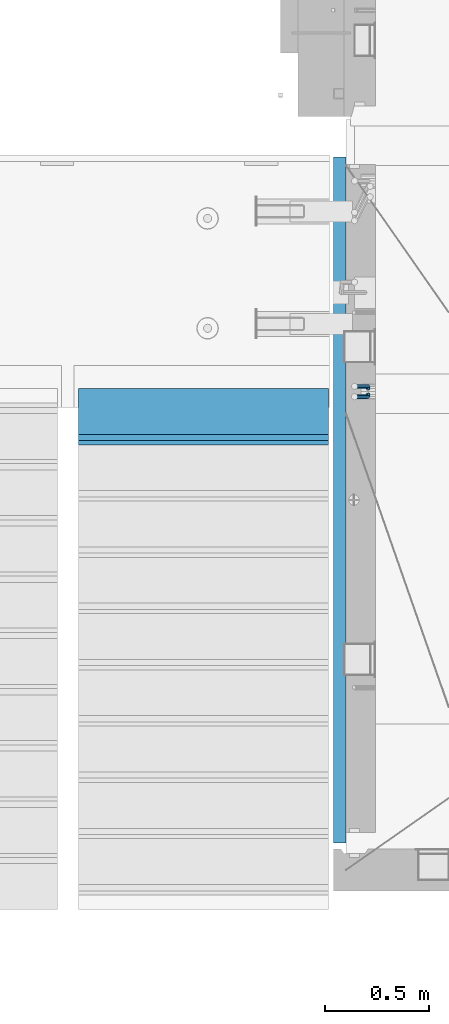
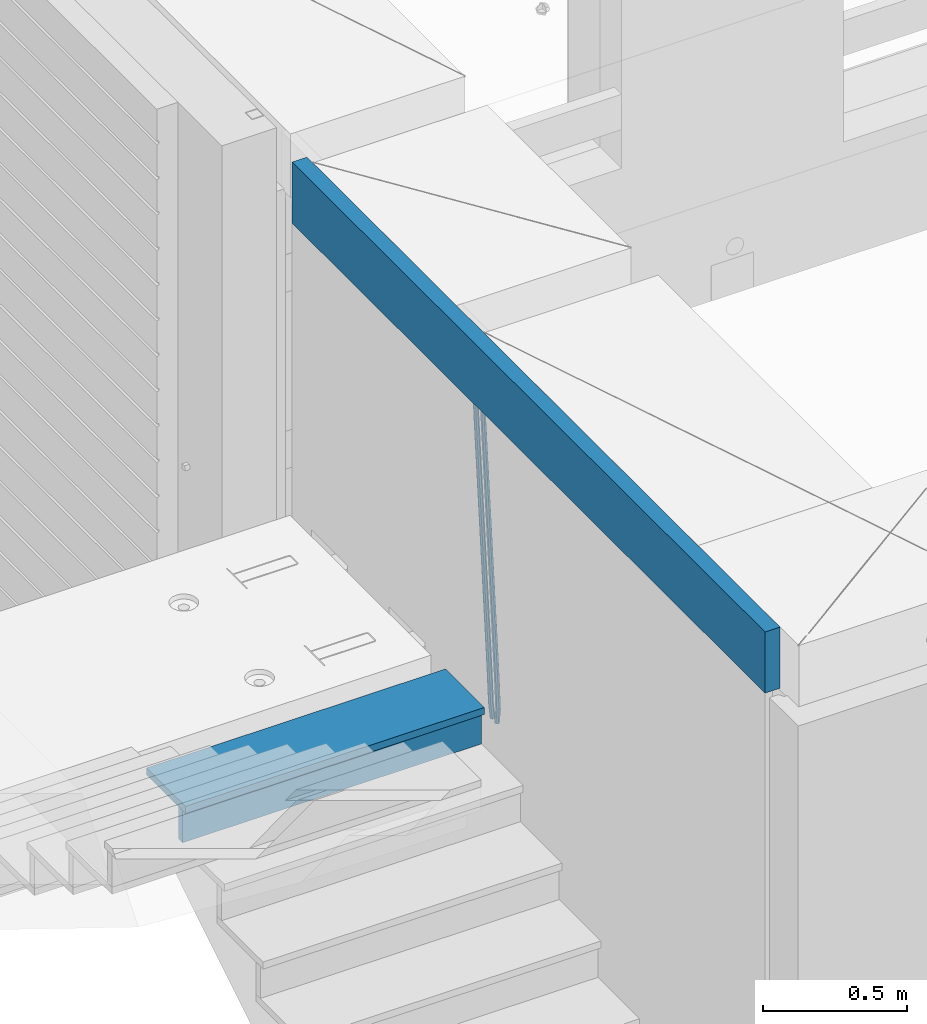
# One storey, part 114 of 334: 5 beams, 2 elements without a shape of their own.
"""IFC2X3 building model written with IfcOpenShell, lengths in millimetres."""

from ifc_helpers import new_model, si_unit, frame, origin_with_axes, place, context, subcontext, project, spatial, faceted_brep, material, type_object, element, aggregate, save


model = new_model("IFC2X3")

# Units and contexts
model_context = context("Model", 3, precision=1e-05, world=origin_with_axes())
body_context = subcontext(model_context, "Body", "Model", "MODEL_VIEW")
ifc_project = project(units=[si_unit("LENGTHUNIT", "METRE", prefix="MILLI"), si_unit("AREAUNIT", "SQUARE_METRE"), si_unit("VOLUMEUNIT", "CUBIC_METRE"), si_unit("MASSUNIT", "GRAM", prefix="KILO"), si_unit("TIMEUNIT", "SECOND"), si_unit("PLANEANGLEUNIT", "RADIAN"), si_unit("SOLIDANGLEUNIT", "STERADIAN"), si_unit("THERMODYNAMICTEMPERATUREUNIT", "DEGREE_CELSIUS"), si_unit("LUMINOUSINTENSITYUNIT", "LUMEN")], contexts=[model_context])

# Site, building, storey
site_placement = place(None, origin_with_axes())
site = spatial("IfcSite", under=ifc_project, at=site_placement, CompositionType="ELEMENT")
building_placement = place(site_placement, origin_with_axes())
building = spatial("IfcBuilding", under=site, at=building_placement, CompositionType="ELEMENT")
storey_placement = place(building_placement, origin_with_axes())
storey = spatial("IfcBuildingStorey", under=building, at=storey_placement, Name="3", CompositionType="ELEMENT", Elevation=0.0)

# Assembly, beams
assembly_1_placement = place(storey_placement, origin_with_axes())
assembly_1 = element("IfcElementAssembly", 1, at=assembly_1_placement, inside=storey, AssemblyPlace="NOTDEFINED", PredefinedType="REINFORCEMENT_UNIT")
ifc_material_1 = material()
beam_type_1 = type_object("IfcBeamType", Name="D20", PredefinedType="NOTDEFINED")
beam_1_placement = place(assembly_1_placement, frame((22375.0000022791, 19290.4700000039, 88985.0), z_axis=(-0.15890508605452, 0.973589036334047, -0.163931577056242), x_axis=(-0.0263727870048703, 0.161796289029781, 0.986471711181718)))
beam_1 = element("IfcBeam", 2, at=beam_1_placement, type_object=beam_type_1, material=ifc_material_1, Name="JM20", ObjectType="D20", context=body_context, shape_type="Brep", body=[
    faceted_brep([(0.0, -10.0, 0.0), (-4.19531716033816e-08, -7.07106781186667, -7.07106781187031), (60.5120847452927, -7.07106784077769, -7.0710678127632), (60.5120847456128, -10.000000028911, -8.96534402272664e-10), (0.0, 0.0, -10.0), (60.5120847479557, -2.89146555587649e-08, -10.0000000008984), (4.196772351861e-08, 7.07106781186303, -7.07106781186667), (60.5120847520593, 7.07106778294838, -7.0710678127632), (0.0, 10.0, 0.0), (60.5120847551734, 9.99999997108898, -8.94715412869118e-10), (4.196772351861e-08, 7.07106781185939, 7.07106781185939), (60.512084755479, 7.07106778295201, 7.07106781097195), (0.0, 0.0, 10.0), (60.512084752816, -2.89110175799578e-08, 9.9999999991071), (-4.19531716033816e-08, -7.07106781187031, 7.07106781185939), (60.5120847487415, -7.07106784077769, 7.07106781096832), (61.1107048256381, -7.07106784106145, -7.07106781277048), (61.616696962592, -10.0000000294385, -9.12905306904577e-10), (61.0120847479702, -2.91511241812259e-08, -10.0000000009038), (61.3786070335627, 7.07106778254092, -7.0710678127723), (61.9955678984406, 9.99999997037958, -9.2018126451876e-10), (62.5015600354091, 7.07106778200614, 7.07106781093921), (62.6001801130624, -2.9907823773101e-08, 9.99999999907436), (62.2336578274699, -7.07106784159623, 7.07106781094103), (61.7013993430301, -7.09359767751084, -7.16550506250837), (62.7066844218498, -10.0415735305724, -0.174261679103211), (61.505464887392, -0.0188181720659486, -10.0788791204338), (62.2336568017054, 7.03845510227256, -7.207768842012), (63.4594101385883, 9.94416717476997, -0.234031689273024), (64.464695217408, 6.99619132171574, 6.75721169413032), (64.6606296730461, -0.0785881837327906, 9.67058575205397), (63.9324377587182, -7.1358614580713, 6.79947547363395), (179.287252569251, -11.5784709304826, -25.9645361348155), (180.292537648071, -14.5264467835441, -18.973292751414), (179.091318113613, -4.50369142503769, -28.877910192741), (179.819510027926, 2.55358184929719, -26.0067999143191), (181.045263364809, 5.45929392180187, -19.033062761582), (182.050548443614, 2.511318068744, -12.0418193781786), (182.246482899252, -4.56346143670453, -9.12844532025679), (181.518290984939, -11.6207347110394, -11.9995555986786), (179.796944029818, -11.5979112078276, -26.0460230258138), (180.785917787493, -14.5452649264626, -19.0521718709458), (179.631039013402, -4.52427706319941, -28.9641980384947), (180.385387646791, 2.53199856077117, -26.0972695639282), (181.618102731314, 5.43744510340548, -19.1246454201662), (182.607076488988, 2.49009138477413, -12.1307942652963), (182.772981505375, -4.58354275985403, -9.21261925261729), (182.018632872001, -11.6398183838246, -12.0795477271802), (180.306575384253, -11.6215474691344, -26.1267734773298), (181.279244090445, -14.5681079330752, -19.1303214631914), (180.170689328603, -4.54931932109321, -29.0497458967745), (180.951186131948, 2.5057611781267, -26.1870011206463), (182.190861352254, 5.41092355571527, -19.2154962132006), (183.16353005846, 2.46436309177807, -12.2190441990567), (183.299416114096, -4.60786505625947, -9.29607177961748), (182.518919310765, -11.662945555483, -12.1588165557403), (300.637581828458, -17.193417372393, -45.2021641841727), (301.610250534635, -20.1399778363302, -38.2057121700307), (300.501695772793, -10.1211892243555, -48.125136603612), (301.282192576138, -3.06610872513556, -45.2623918274874), (302.521867796473, -0.160946347543359, -38.2908869200398), (303.494536502651, -3.10750681148056, -31.2944349058978), (303.630422558286, -10.1797349595217, -28.3714624864531), (302.849925754956, -17.2348154587417, -31.2342072625831), (301.135146648914, -17.2164568742628, -45.2810403078945), (302.103568397841, -20.1628206848691, -38.2839150477537), (301.007079483054, -10.1445907761881, -48.2052522115043), (301.794386909154, -3.08982563961035, -45.3435870847131), (303.035874914756, -0.184747202180006, -38.3723695478091), (304.004296663683, -3.13111101278264, -31.3752442876664), (304.132363829543, -10.2029771108573, -28.4510323840584), (303.345056403443, -17.2577422474315, -31.3126975108532), (301.632689949649, -17.2405558216851, -45.3597353949606), (302.596865217929, -20.1867113775443, -38.3619373656909), (301.512440876206, -10.1690694440185, -48.2851865283189), (302.306558273951, -3.11463305844518, -45.424601167904), (303.549858941391, -0.209639824737678, -38.4536714215171), (304.514034209686, -3.15579538060047, -31.4558733922438), (304.634283283129, -10.2272817582634, -28.5304222588836), (303.840165885384, -17.2817181438368, -31.3910076193022), (1282.62444446853, -64.7506719518351, -200.525713980774), (1283.58861973681, -67.6968275076943, -193.527915951503), (1282.50419539507, -57.6791855741649, -203.451165114133), (1283.29831279283, -50.6247491885915, -200.590579753716), (1284.54161346027, -47.7197559548877, -193.619650007329), (1285.50578872855, -50.6659115107432, -186.621851978058), (1285.62603780199, -57.7373978884098, -183.696400844703), (1284.83192040426, -64.7918342739831, -186.556986205121), (1283.16036625447, -64.7766270183929, -200.610482102403), (1284.18303170854, -67.7256152948248, -193.621935615638), (1282.99823367732, -57.703112193376, -203.529308414698), (1283.79160904189, -50.6486398706256, -200.668605684988), (1285.07574381966, -47.7456242614098, -193.704134774427), (1286.09840927372, -50.6946125378345, -186.715588287659), (1286.26054185088, -57.7681273628514, -183.796761975365), (1285.4671664863, -64.8225996856127, -186.657464705073), (1283.69517474226, -64.7992414390355, -200.702893843656), (1284.77620887742, -67.7506978399178, -193.72443311951), (1283.49124566819, -57.7239592457336, -203.61449796867), (1284.28388054106, -50.6694556112197, -200.753667286384), (1285.60876460234, -47.7681630887928, -193.796237610821), (1286.68979873748, -50.7196194896715, -186.817776886675), (1286.89372781155, -57.7949016829771, -183.906172761662), (1286.10109293868, -64.8494053174909, -186.767003443949), (1305.19726392522, -65.7084590385093, -204.418327587487), (1306.27829806038, -68.6599154393916, -197.43986686334), (1304.99333485115, -58.6331768452073, -207.3299317125), (1305.78596972401, -51.5786732107008, -204.469101030216), (1307.11085378527, -48.6773806882629, -197.511671354648), (1308.19188792045, -51.6288370891452, -190.533210630503), (1308.39581699451, -58.7041192824508, -187.62160650549), (1307.60318212165, -65.758622916961, -190.482437187782), (1305.83218118416, -65.7353065667266, -204.528037531872), (1306.8626665273, -68.6846255078017, -197.540842275655), (1305.64065308902, -58.6605487498273, -207.441784472648), (1306.40027680244, -51.6046492357418, -204.575249657393), (1307.66607505539, -48.7008582650778, -197.607610303868), (1308.69656039854, -51.6501772061529, -190.620415047653), (1308.88808849367, -58.7249350230522, -187.706668106881), (1308.12846478027, -65.7808345371377, -190.573202922138), (1306.46882402551, -65.7602792894941, -204.627733284394), (1307.44862319478, -68.7076100329687, -197.632600773693), (1306.28973061276, -58.6860092309689, -207.543427447275), (1307.01625344875, -51.6288113137889, -204.671709165457), (1308.2228053096, -48.7226963654903, -197.694792061111), (1309.20260447887, -51.6700271089649, -190.699659550409), (1309.38169789161, -58.74429716749, -187.783965387529), (1308.65517505561, -65.80149508467, -190.655683669345), (1405.22131312029, -69.6339088545756, -220.091982741469), (1406.20111228956, -72.5812395980538, -213.096850230768), (1405.04221970754, -62.5596387960541, -223.007676904353), (1405.76874254357, -55.5024408788704, -220.135958622533), (1406.97529440439, -52.5963259305718, -213.159041518189), (1407.95509357366, -55.54365667405, -206.163909007488), (1408.13418698641, -62.6179267325751, -203.248214844601), (1407.40766415041, -69.6751246497552, -206.119933126425)], [[[0, 1, 2, 3]], [[1, 4, 5, 2]], [[4, 6, 7, 5]], [[6, 8, 9, 7]], [[8, 10, 11, 9]], [[10, 12, 13, 11]], [[12, 14, 15, 13]], [[14, 0, 3, 15]], [[14, 12, 10, 8, 6, 4, 1, 0]], [[3, 2, 16, 17]], [[2, 5, 18, 16]], [[5, 7, 19, 18]], [[7, 9, 20, 19]], [[9, 11, 21, 20]], [[11, 13, 22, 21]], [[13, 15, 23, 22]], [[15, 3, 17, 23]], [[17, 16, 24, 25]], [[16, 18, 26, 24]], [[18, 19, 27, 26]], [[19, 20, 28, 27]], [[20, 21, 29, 28]], [[21, 22, 30, 29]], [[22, 23, 31, 30]], [[23, 17, 25, 31]], [[25, 24, 32, 33]], [[24, 26, 34, 32]], [[26, 27, 35, 34]], [[27, 28, 36, 35]], [[28, 29, 37, 36]], [[29, 30, 38, 37]], [[30, 31, 39, 38]], [[31, 25, 33, 39]], [[33, 32, 40, 41]], [[32, 34, 42, 40]], [[34, 35, 43, 42]], [[35, 36, 44, 43]], [[36, 37, 45, 44]], [[37, 38, 46, 45]], [[38, 39, 47, 46]], [[39, 33, 41, 47]], [[41, 40, 48, 49]], [[40, 42, 50, 48]], [[42, 43, 51, 50]], [[43, 44, 52, 51]], [[44, 45, 53, 52]], [[45, 46, 54, 53]], [[46, 47, 55, 54]], [[47, 41, 49, 55]], [[49, 48, 56, 57]], [[48, 50, 58, 56]], [[50, 51, 59, 58]], [[51, 52, 60, 59]], [[52, 53, 61, 60]], [[53, 54, 62, 61]], [[54, 55, 63, 62]], [[55, 49, 57, 63]], [[57, 56, 64, 65]], [[56, 58, 66, 64]], [[58, 59, 67, 66]], [[59, 60, 68, 67]], [[60, 61, 69, 68]], [[61, 62, 70, 69]], [[62, 63, 71, 70]], [[63, 57, 65, 71]], [[65, 64, 72, 73]], [[64, 66, 74, 72]], [[66, 67, 75, 74]], [[67, 68, 76, 75]], [[68, 69, 77, 76]], [[69, 70, 78, 77]], [[70, 71, 79, 78]], [[71, 65, 73, 79]], [[73, 72, 80, 81]], [[72, 74, 82, 80]], [[74, 75, 83, 82]], [[75, 76, 84, 83]], [[76, 77, 85, 84]], [[77, 78, 86, 85]], [[78, 79, 87, 86]], [[79, 73, 81, 87]], [[81, 80, 88, 89]], [[80, 82, 90, 88]], [[82, 83, 91, 90]], [[83, 84, 92, 91]], [[84, 85, 93, 92]], [[85, 86, 94, 93]], [[86, 87, 95, 94]], [[87, 81, 89, 95]], [[89, 88, 96, 97]], [[88, 90, 98, 96]], [[90, 91, 99, 98]], [[91, 92, 100, 99]], [[92, 93, 101, 100]], [[93, 94, 102, 101]], [[94, 95, 103, 102]], [[95, 89, 97, 103]], [[97, 96, 104, 105]], [[96, 98, 106, 104]], [[98, 99, 107, 106]], [[99, 100, 108, 107]], [[100, 101, 109, 108]], [[101, 102, 110, 109]], [[102, 103, 111, 110]], [[103, 97, 105, 111]], [[105, 104, 112, 113]], [[104, 106, 114, 112]], [[106, 107, 115, 114]], [[107, 108, 116, 115]], [[108, 109, 117, 116]], [[109, 110, 118, 117]], [[110, 111, 119, 118]], [[111, 105, 113, 119]], [[113, 112, 120, 121]], [[112, 114, 122, 120]], [[114, 115, 123, 122]], [[115, 116, 124, 123]], [[116, 117, 125, 124]], [[117, 118, 126, 125]], [[118, 119, 127, 126]], [[119, 113, 121, 127]], [[121, 120, 128, 129]], [[120, 122, 130, 128]], [[122, 123, 131, 130]], [[123, 124, 132, 131]], [[124, 125, 133, 132]], [[125, 126, 134, 133]], [[126, 127, 135, 134]], [[127, 121, 129, 135]], [[130, 131, 132, 133, 134, 135, 129, 128]]]),
])
beam_2_placement = place(assembly_1_placement, frame((22375.0000022791, 19260.4700000039, 88985.0), z_axis=(-0.158495816053634, -0.973655762329485, -0.163931488055477), x_axis=(-0.0263727879979646, -0.161796198987477, 0.986471725923465)))
beam_2 = element("IfcBeam", 3, at=beam_2_placement, type_object=beam_type_1, material=ifc_material_1, Name="JM20", ObjectType="D20", context=body_context, shape_type="Brep", body=[
    faceted_brep([(0.0, -10.0, 0.0), (-4.19531716033816e-08, -7.07106781186667, -7.07106781187031), (60.5120052037528, -7.07106781749098, -7.07106782543269), (60.5120052045822, -10.0000000056316, -1.35623849928379e-08), (0.0, 0.0, -10.0), (60.512005203942, -5.62431523576379e-09, -10.0000000135624), (4.196772351861e-08, 7.07106781186303, -7.07106781186667), (60.5120052050625, 7.07106780623872, -7.07106782543269), (0.0, 10.0, 0.0), (60.5120052064449, 9.99999999437205, -1.35623849928379e-08), (4.196772351861e-08, 7.07106781185939, 7.07106781185939), (60.5120052072889, 7.07106780623872, 7.07106779830065), (0.0, 0.0, 10.0), (60.5120052070852, -5.62795321457088e-09, 9.99999998643762), (-4.19531716033816e-08, -7.07106781187031, 7.07106781185939), (60.5120052059501, -7.07106781749098, 7.07106779830065), (61.3783176868601, -7.07106781757102, -7.07106782562914), (61.9952377020818, -10.0000000057662, -1.38970790430903e-08), (61.0120052039565, -5.67160896025598e-09, -10.0000000136788), (61.1108811377926, 7.07106780618051, -7.07106782556366), (61.6170253073215, 9.99999999427382, -1.38097675517201e-08), (62.2339453225432, 7.07106780607864, 7.07106779791502), (62.6002578054613, -5.81712811253965e-09, 9.99999998597195), (62.5013818716106, -7.07106781767652, 7.07106779785681), (62.2331604305218, -7.03851970548931, -7.2077492888784), (63.4588326085068, -9.94427367315438, -0.23401532828575), (61.5053853412101, 0.0187854284049536, -10.0788869429962), (61.7018281175842, 7.09356809489327, -7.16555479231465), (62.7074152454443, 10.041516558791, -0.174343299004249), (63.9330874234438, 7.13576259111869, 6.79939066157385), (64.6608625127556, 0.078457457228069, 9.6705283156989), (64.4644197363668, -6.99632520926025, 6.75719616502465), (179.818932802998, -2.5614449136192, -26.0086288006423), (181.044604980983, -5.46719888128791, -19.034894840057), (179.091157713687, 4.49586022027506, -28.8797664547601), (179.287600490061, 11.5706428867597, -25.9664343040859), (180.293187617921, 14.5185913506575, -18.9752228107754), (181.51885979592, 11.6128373829924, -12.0014888501901), (182.246634885232, 4.55553224909454, -9.13035119606502), (182.050192108843, -2.51925041739014, -12.0436833467465), (180.384803383684, -2.53989940806059, -26.0991062826724), (181.617449868121, -5.44538782921518, -19.126487449299), (179.630864755702, 4.51640954987306, -28.9660606284815), (179.797281007268, 11.5900489573214, -26.0479275136822), (180.786567755189, 14.5373767847341, -19.0541097400928), (182.019214239626, 11.6318883635759, -12.0814909067267), (182.773152867594, 4.5755794056422, -9.21453656090307), (182.606736616028, -2.49806000179888, -12.1326696757169), (180.950594849404, -2.51369963445904, -26.1888475202795), (182.190214025846, -5.41890367426822, -19.2173500092686), (180.170501221772, 4.54141556354443, -29.051616675737), (180.306901410135, 11.613651120846, -26.1286861303379), (181.279894034014, 14.5601873642845, -19.132268955691), (182.519513210456, 11.6549833244717, -12.16077144468), (183.299606838089, 4.59986812646821, -9.29800228921522), (183.163206649726, -2.4723674308334, -12.2209328346216), (301.281596738394, 3.05026059481679, -45.2665532172323), (302.521215914836, 0.145056555003976, -38.2950557062213), (300.501503110776, 10.1053757928166, -48.1293223726971), (300.637903299124, 17.1776113501182, -45.2063918272906), (301.610895923019, 20.1241475935603, -38.2099746526364), (302.850515099461, 17.2189435537439, -31.2384771416328), (303.630608727079, 10.163828355744, -28.375707986168), (303.494208538745, 3.09159279844243, -31.2986385315744), (301.793789297284, 3.07394376027514, -45.3477580501058), (303.035224417355, 0.168823687501572, -38.3765484452742), (301.006883331909, 10.128743964, -48.2094471532764), (301.135465363477, 17.2006180191747, -45.285277089446), (302.104213781728, 20.14695801567, -38.2881870233177), (303.345648901799, 17.2418379429, -31.3169774184789), (304.132554867159, 10.1870377391679, -28.455288315301), (304.003972835591, 3.11516368399316, -31.3794583791459), (302.305958891287, 3.09871749445665, -45.4287821432372), (303.549209831341, 0.193682665365486, -38.4578608624288), (301.512241238641, 10.1531893083702, -48.2893910778876), (301.633005909636, 17.2246841938904, -45.3639817491057), (302.597510597858, 20.1708163533331, -38.3662192661868), (303.840761537926, 17.2657815242455, -31.3952979853784), (304.634479190572, 10.211309710332, -28.5346890507208), (304.513714519577, 3.13981482481177, -31.4600983795099), (1283.29235311947, 50.544232039254, -200.613633821762), (1284.53560405952, 47.6391972101628, -193.642712540946), (1282.49863546679, 57.5987038531639, -203.474242756405), (1282.6194001378, 64.6701987386878, -200.548833427623), (1283.58390482602, 67.6163308981268, -193.551070944704), (1284.82715576609, 64.7112960690356, -186.580149663889), (1285.62087341874, 57.6568242551293, -183.719540729246), (1285.50010874774, 50.5853293696091, -186.644950058035), (1283.86584870378, 50.5719692160856, -200.704356616399), (1285.05399320807, 47.6642691581874, -193.72471790167), (1283.12497041782, 57.628996611762, -203.573324351266), (1283.26535480202, 64.701440406865, -200.651018717188), (1284.20476658808, 67.6463589453451, -193.649286721222), (1285.39291109238, 64.7386588874433, -186.6696480065), (1286.13378937833, 57.6816314917669, -183.800680271634), (1285.99340499415, 50.6091876966675, -186.722985905704), (1284.44060590031, 50.5936921758439, -200.788496023008), (1285.57352274218, 47.68390478734, -193.800772463459), (1283.75268322045, 57.6527210297136, -203.665215993606), (1283.91273047855, 64.7259079835276, -200.745788831606), (1284.82699416149, 67.6698760489453, -193.740375374167), (1285.95991100336, 64.7600886604341, -186.752651814619), (1286.64783368325, 57.7010598065717, -183.875931844028), (1286.48778642512, 50.6278728527504, -186.795359006021), (1306.02894027183, 51.4096237058839, -203.948838607132), (1307.16185711371, 48.4998363173727, -196.961115047583), (1305.34101759194, 58.4686525597535, -206.825558577722), (1305.50106485008, 65.5418395135639, -203.90613141573), (1306.415328533, 68.4858075789816, -196.900717958291), (1307.54824537487, 65.5760201904777, -189.912994398743), (1308.23616805475, 58.5169913366044, -187.036274428152), (1308.07612079663, 51.4438043827904, -189.955701590145), (1306.55429855913, 51.4294796328759, -204.025746447209), (1307.74597489809, 48.5219130607366, -197.046624762064), (1305.83539902292, 58.4873377158401, -206.897931678046), (1306.0103978878, 65.5610897659317, -203.980693299985), (1306.97678319212, 68.507027769072, -196.982909990227), (1308.16845953107, 65.5994611969327, -190.00378830509), (1308.88735906727, 58.5416031139684, -187.131603074253), (1308.71236020241, 51.4678510638769, -190.048841452306), (1307.07832423707, 51.4505295560484, -204.110977857723), (1308.32861102538, 48.5453173445967, -197.141389009383), (1306.32852641959, 58.507146466156, -206.978137563652), (1306.51843896537, 65.5814975934481, -204.063324856921), (1307.5368136808, 68.5295239925508, -197.073997489359), (1308.78710046913, 65.6243117811064, -190.104408641026), (1309.53689828661, 58.5676948709952, -187.237248935096), (1309.34698574082, 51.4933437436994, -190.152061641827), (1405.73383542724, 55.413485988287, -220.157039583137), (1406.98412221558, 52.5082737768425, -213.187450734797), (1404.98403760976, 62.4701028983982, -223.024199289066), (1405.17395015556, 69.544454025694, -220.109386582335), (1406.19232487098, 72.492480424793, -213.12005921478), (1407.44261165931, 69.5872682133449, -206.15047036644), (1408.1924094768, 62.5306513032374, -203.28331066051), (1408.00249693099, 55.4563001759452, -206.198123367241)], [[[0, 1, 2, 3]], [[1, 4, 5, 2]], [[4, 6, 7, 5]], [[6, 8, 9, 7]], [[8, 10, 11, 9]], [[10, 12, 13, 11]], [[12, 14, 15, 13]], [[14, 0, 3, 15]], [[14, 12, 10, 8, 6, 4, 1, 0]], [[3, 2, 16, 17]], [[2, 5, 18, 16]], [[5, 7, 19, 18]], [[7, 9, 20, 19]], [[9, 11, 21, 20]], [[11, 13, 22, 21]], [[13, 15, 23, 22]], [[15, 3, 17, 23]], [[17, 16, 24, 25]], [[16, 18, 26, 24]], [[18, 19, 27, 26]], [[19, 20, 28, 27]], [[20, 21, 29, 28]], [[21, 22, 30, 29]], [[22, 23, 31, 30]], [[23, 17, 25, 31]], [[25, 24, 32, 33]], [[24, 26, 34, 32]], [[26, 27, 35, 34]], [[27, 28, 36, 35]], [[28, 29, 37, 36]], [[29, 30, 38, 37]], [[30, 31, 39, 38]], [[31, 25, 33, 39]], [[33, 32, 40, 41]], [[32, 34, 42, 40]], [[34, 35, 43, 42]], [[35, 36, 44, 43]], [[36, 37, 45, 44]], [[37, 38, 46, 45]], [[38, 39, 47, 46]], [[39, 33, 41, 47]], [[41, 40, 48, 49]], [[40, 42, 50, 48]], [[42, 43, 51, 50]], [[43, 44, 52, 51]], [[44, 45, 53, 52]], [[45, 46, 54, 53]], [[46, 47, 55, 54]], [[47, 41, 49, 55]], [[49, 48, 56, 57]], [[48, 50, 58, 56]], [[50, 51, 59, 58]], [[51, 52, 60, 59]], [[52, 53, 61, 60]], [[53, 54, 62, 61]], [[54, 55, 63, 62]], [[55, 49, 57, 63]], [[57, 56, 64, 65]], [[56, 58, 66, 64]], [[58, 59, 67, 66]], [[59, 60, 68, 67]], [[60, 61, 69, 68]], [[61, 62, 70, 69]], [[62, 63, 71, 70]], [[63, 57, 65, 71]], [[65, 64, 72, 73]], [[64, 66, 74, 72]], [[66, 67, 75, 74]], [[67, 68, 76, 75]], [[68, 69, 77, 76]], [[69, 70, 78, 77]], [[70, 71, 79, 78]], [[71, 65, 73, 79]], [[73, 72, 80, 81]], [[72, 74, 82, 80]], [[74, 75, 83, 82]], [[75, 76, 84, 83]], [[76, 77, 85, 84]], [[77, 78, 86, 85]], [[78, 79, 87, 86]], [[79, 73, 81, 87]], [[81, 80, 88, 89]], [[80, 82, 90, 88]], [[82, 83, 91, 90]], [[83, 84, 92, 91]], [[84, 85, 93, 92]], [[85, 86, 94, 93]], [[86, 87, 95, 94]], [[87, 81, 89, 95]], [[89, 88, 96, 97]], [[88, 90, 98, 96]], [[90, 91, 99, 98]], [[91, 92, 100, 99]], [[92, 93, 101, 100]], [[93, 94, 102, 101]], [[94, 95, 103, 102]], [[95, 89, 97, 103]], [[97, 96, 104, 105]], [[96, 98, 106, 104]], [[98, 99, 107, 106]], [[99, 100, 108, 107]], [[100, 101, 109, 108]], [[101, 102, 110, 109]], [[102, 103, 111, 110]], [[103, 97, 105, 111]], [[105, 104, 112, 113]], [[104, 106, 114, 112]], [[106, 107, 115, 114]], [[107, 108, 116, 115]], [[108, 109, 117, 116]], [[109, 110, 118, 117]], [[110, 111, 119, 118]], [[111, 105, 113, 119]], [[113, 112, 120, 121]], [[112, 114, 122, 120]], [[114, 115, 123, 122]], [[115, 116, 124, 123]], [[116, 117, 125, 124]], [[117, 118, 126, 125]], [[118, 119, 127, 126]], [[119, 113, 121, 127]], [[121, 120, 128, 129]], [[120, 122, 130, 128]], [[122, 123, 131, 130]], [[123, 124, 132, 131]], [[124, 125, 133, 132]], [[125, 126, 134, 133]], [[126, 127, 135, 134]], [[127, 121, 129, 135]], [[130, 131, 132, 133, 134, 135, 129, 128]]]),
])
ifc_material_2 = material(Name="CONCRETE/C25/30")
beam_type_2 = type_object("IfcBeamType", Name="260X60", PredefinedType="NOTDEFINED")
beam_3_placement = place(assembly_1_placement, frame((22240.0000000001, 20400.0, 90600.0), z_axis=(0.0, 0.0, 1.0), x_axis=(0.0, -1.0, 0.0)))
beam_3 = element("IfcBeam", 4, at=beam_3_placement, type_object=beam_type_2, material=ifc_material_2, ObjectType="260X60", context=body_context, shape_type="Brep", body=[
    faceted_brep([(0.0, 30.0, -130.0), (0.0, 30.0, 130.0), (3290.0, 30.0, 130.0), (3290.0, 30.0, -130.0), (0.0, -30.0, 130.0), (3290.0, -30.0, 130.0), (0.0, -30.0, -130.0), (3290.0, -30.0, -130.0)], [[[0, 1, 2, 3]], [[1, 4, 5, 2]], [[4, 6, 7, 5]], [[6, 0, 3, 7]], [[5, 7, 3, 2]], [[6, 4, 1, 0]]]),
])
aggregate(assembly_1, [beam_1, beam_2, beam_3])

assembly_2_placement = place(storey_placement, origin_with_axes())
assembly_2 = element("IfcElementAssembly", 5, at=assembly_2_placement, inside=storey, Name="E9", AssemblyPlace="NOTDEFINED", PredefinedType="NOTDEFINED")
ifc_material_3 = material(Name="Undefined/C32/40")
beam_type_3 = type_object("IfcBeamType", PredefinedType="NOTDEFINED")
beam_4_placement = place(assembly_2_placement, frame((20985.002175553, 19055.001025346, 89161.803607297), z_axis=(0.0, -1.0, 0.0), x_axis=(1.0, 0.0, 0.0)))
beam_4 = element("IfcBeam", 6, at=beam_4_placement, type_object=beam_type_3, material=ifc_material_3, Name="E9", context=body_context, shape_type="Brep", body=[
    faceted_brep([(0.0, 68.5, -15.0), (0.0, 68.5, 15.0), (1200.0, 68.5, 15.0), (1200.0, 68.5, -15.0), (0.0, -68.5, 15.0), (1200.0, -68.5, 15.0), (0.0, -68.5, -15.0), (1200.0, -68.5, -15.0)], [[[0, 1, 2, 3]], [[1, 4, 5, 2]], [[4, 6, 7, 5]], [[6, 0, 3, 7]], [[5, 7, 3, 2]], [[6, 4, 1, 0]]]),
])
beam_type_4 = type_object("IfcBeamType", PredefinedType="NOTDEFINED")
beam_5_placement = place(assembly_2_placement, frame((20985.002175553, 19155.001025346, 89245.003607297), z_axis=(0.0, -1.0, 0.0), x_axis=(1.0, 0.0, 0.0)))
beam_5 = element("IfcBeam", 7, at=beam_5_placement, type_object=beam_type_4, material=ifc_material_3, Name="E9", context=body_context, shape_type="Brep", body=[
    faceted_brep([(0.0, 15.0, -135.0), (0.0, 15.0, 135.0), (1200.0, 15.0, 135.0), (1200.0, 15.0, -135.0), (0.0, -15.0, 135.0), (1200.0, -15.0, 135.0), (0.0, -15.0, -135.0), (1200.0, -15.0, -135.0)], [[[0, 1, 2, 3]], [[1, 4, 5, 2]], [[4, 6, 7, 5]], [[6, 0, 3, 7]], [[5, 7, 3, 2]], [[6, 4, 1, 0]]]),
])
aggregate(assembly_2, [beam_5, beam_4])

save(model, "model.ifc")
